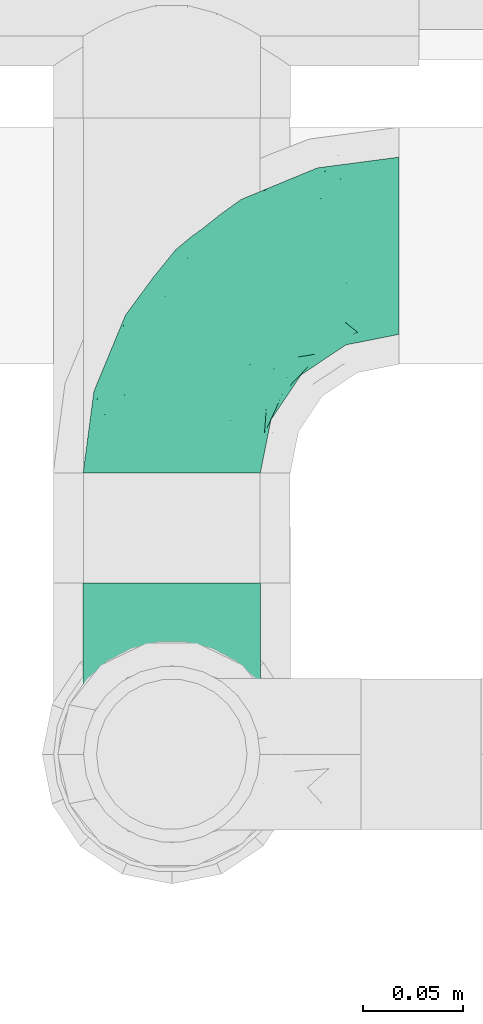
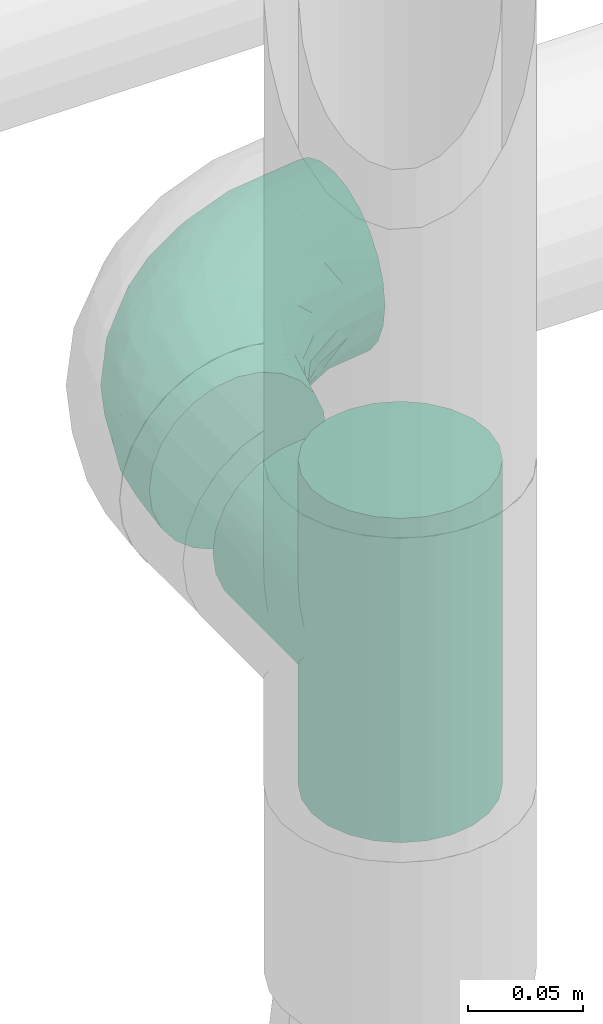
# One storey, part 707 of 827: 2 flow fittings.
"""IFC2X3 building model written with IfcOpenShell, lengths in millimetres."""

import ifcopenshell
import ifcopenshell.guid

model = None  # the IFC model being written
_history = None  # IfcOwnerHistory: only IFC2X3 demands one
_inside = {}  # id of a spatial element -> (the spatial element, [elements in it])
_under = {}  # id of a project, library or spatial element -> (it, [spatial elements below it])
_declared = {}  # id of a project -> (the project, [libraries it declares])
_typed = {}  # id of a type object -> (the type object, [elements of that type])
_made_of = {}  # id of a material, layer set ... -> (it, [elements and type objects made of it])


def new_model(schema):
    """Start an empty IFC model of exactly this schema.

    Asked for "IFC4X3", IfcOpenShell would pick the latest addendum, in which some entities
    have other attributes; the version numbers below select the first issue.
    IFC2X3 requires an IfcOwnerHistory on every rooted entity: one is made here for all.
    """
    global model, _history
    if schema == "IFC4X3":
        model = ifcopenshell.file(schema_version=(4, 3, 0, 0))
    else:
        model = ifcopenshell.file(schema=schema)
    _inside.clear()
    _under.clear()
    _declared.clear()
    _typed.clear()
    _made_of.clear()
    _history = None
    if model.schema == "IFC2X3":
        org = make("IfcOrganization", Name="unknown")
        user = make(
            "IfcPersonAndOrganization",
            ThePerson=make("IfcPerson", FamilyName="unknown"),
            TheOrganization=org,
        )
        app = make(
            "IfcApplication",
            ApplicationDeveloper=org,
            Version="unknown",
            ApplicationFullName="unknown",
            ApplicationIdentifier="unknown",
        )
        _history = make(
            "IfcOwnerHistory",
            OwningUser=user,
            OwningApplication=app,
            ChangeAction="ADDED",
            CreationDate=0,
        )
    return model


def make(cls, **values):
    """One entity of the class cls with the attributes given. An attribute that is None is left unset."""
    return model.create_entity(
        cls, **{name: value for name, value in values.items() if value is not None}
    )


def entity(cls, *values):
    """Any entity or typed value of the class cls, its attributes in the order of the schema. None: left unset."""
    e = model.create_entity(cls)
    for i, value in enumerate(values):
        if value is not None:
            e[i] = value
    return e


def rooted(cls, **values):
    """An entity with a GlobalId (a new one), such as an element, a storey or a relation."""
    return make(cls, GlobalId=ifcopenshell.guid.new(), OwnerHistory=_history, **values)


def si_unit(unit_type, name, prefix=None):
    """IfcSIUnit, for example si_unit("LENGTHUNIT", "METRE", prefix="MILLI")."""
    return make("IfcSIUnit", UnitType=unit_type, Prefix=prefix, Name=name)


def converted_unit(unit_type, name, factor, base, dimensions=None, offset=None):
    """IfcConversionBasedUnit, such as the inch: factor (a typed value) times the base unit."""
    return make(
        "IfcConversionBasedUnit"
        if offset is None
        else "IfcConversionBasedUnitWithOffset",
        ConversionOffset=offset,
        Dimensions=None
        if dimensions is None
        else entity("IfcDimensionalExponents", *dimensions),
        UnitType=unit_type,
        Name=name,
        ConversionFactor=make(
            "IfcMeasureWithUnit", ValueComponent=factor, UnitComponent=base
        ),
    )


def derived_unit(unit_type, elements):
    """IfcDerivedUnit: a product of units, each with its exponent."""
    return make(
        "IfcDerivedUnit",
        Elements=[
            make("IfcDerivedUnitElement", Unit=unit, Exponent=power)
            for unit, power in elements
        ],
        UnitType=unit_type,
    )


def assignment(units):
    """IfcUnitAssignment: the units of a project."""
    return None if units is None else make("IfcUnitAssignment", Units=units)


def point(xyz):
    """IfcCartesianPoint."""
    return None if xyz is None else make("IfcCartesianPoint", Coordinates=xyz)


def direction(xyz):
    """IfcDirection."""
    return None if xyz is None else make("IfcDirection", DirectionRatios=xyz)


def frame(location, z_axis=None, x_axis=None):
    """IfcAxis2Placement3D, a coordinate frame: its origin and axes. An axis left out is left unset."""
    return make(
        "IfcAxis2Placement3D",
        Location=point(location),
        Axis=direction(z_axis),
        RefDirection=direction(x_axis),
    )


def origin():
    """The frame at (0, 0, 0) with its axes left unset."""
    return frame((0.0, 0.0, 0.0))


def place(relative_to, where):
    """IfcLocalPlacement: puts the frame where relative to a parent placement (None: the world)."""
    return make(
        "IfcLocalPlacement", PlacementRelTo=relative_to, RelativePlacement=where
    )


def context(
    kind, dimensions, precision=None, world=None, true_north=None, identifier=None
):
    """IfcGeometricRepresentationContext, for example the 3D "Model" context."""
    return make(
        "IfcGeometricRepresentationContext",
        ContextIdentifier=identifier,
        ContextType=kind,
        CoordinateSpaceDimension=dimensions,
        Precision=precision,
        WorldCoordinateSystem=world,
        TrueNorth=true_north,
    )


def subcontext(parent, identifier, kind, view, scale=None):
    """IfcGeometricRepresentationSubContext, for example "Body" below "Model"."""
    return make(
        "IfcGeometricRepresentationSubContext",
        ContextIdentifier=identifier,
        ContextType=kind,
        ParentContext=parent,
        TargetScale=scale,
        TargetView=view,
    )


def project(units=None, contexts=None):
    """IfcProject with its units and contexts."""
    return rooted(
        "IfcProject",
        Name="project",
        RepresentationContexts=contexts,
        UnitsInContext=assignment(units),
    )


def spatial(cls, under=None, at=None, **own):
    """A site, building, storey or space (cls), placed at a placement, below another one or the project."""
    s = rooted(cls, ObjectPlacement=at, **own)
    if under is not None:
        _under.setdefault(under.id(), (under, []))[1].append(s)
    return s


def faces_of(points, faces, orient=None, outer=None):
    """IfcFace entities. A face is a list of loops; a loop is a list of indices into points, from 0.

    orient and outer hold one flag for each loop. By default every Orientation is true, the
    first loop of a face is its IfcFaceOuterBound and the others are IfcFaceBound.
    """
    made = []
    for i, loops in enumerate(faces):
        bounds = []
        for j, loop in enumerate(loops):
            is_outer = j == 0 if outer is None else outer[i][j]
            bounds.append(
                make(
                    "IfcFaceOuterBound" if is_outer else "IfcFaceBound",
                    Bound=make("IfcPolyLoop", Polygon=[points[k] for k in loop]),
                    Orientation=True if orient is None else orient[i][j],
                )
            )
        made.append(make("IfcFace", Bounds=bounds))
    return made


def faceted_brep(points, faces, orient=None, outer=None, voids=None):
    """IfcFacetedBrep: a solid bounded by flat faces; with voids (closed shells), ...WithVoids."""
    shared = [point(p) for p in points]
    hull = make("IfcClosedShell", CfsFaces=faces_of(shared, faces, orient, outer))
    if voids is None:
        return make("IfcFacetedBrep", Outer=hull)
    return make(
        "IfcFacetedBrepWithVoids",
        Outer=hull,
        Voids=[
            make(cls, CfsFaces=faces_of(shared, fs, o, b)) for cls, fs, o, b in voids
        ],
    )


def shape(context_of_items, identifier, shape_type, items):
    """IfcShapeRepresentation: the items that make up one representation, for example the "Body"."""
    return make(
        "IfcShapeRepresentation",
        ContextOfItems=context_of_items,
        RepresentationIdentifier=identifier,
        RepresentationType=shape_type,
        Items=items,
    )


def source(mapping_origin, context_of_items, identifier, shape_type, items):
    """IfcRepresentationMap: a shape defined once, which mapped items show again and again."""
    return make(
        "IfcRepresentationMap",
        MappingOrigin=mapping_origin,
        MappedRepresentation=shape(context_of_items, identifier, shape_type, items),
    )


def transform(
    local_origin,
    x_axis=None,
    y_axis=None,
    z_axis=None,
    scale=None,
    scale2=None,
    scale3=None,
    uniform=True,
):
    """IfcCartesianTransformationOperator3D, or its non-uniform kind. x_axis, y_axis, z_axis: its Axis1, 2, 3."""
    if uniform:
        return make(
            "IfcCartesianTransformationOperator3D",
            Axis1=direction(x_axis),
            Axis2=direction(y_axis),
            LocalOrigin=point(local_origin),
            Scale=scale,
            Axis3=direction(z_axis),
        )
    return make(
        "IfcCartesianTransformationOperator3DnonUniform",
        Axis1=direction(x_axis),
        Axis2=direction(y_axis),
        LocalOrigin=point(local_origin),
        Scale=scale,
        Axis3=direction(z_axis),
        Scale2=scale2,
        Scale3=scale3,
    )


def mapped(mapping_source, mapping_target):
    """IfcMappedItem: shows the shape of a source again, moved by a transform."""
    return make(
        "IfcMappedItem", MappingSource=mapping_source, MappingTarget=mapping_target
    )


def material(Name=None, Category=None):
    """IfcMaterial."""
    return make("IfcMaterial", Name=Name, Category=Category)


def made_of(thing, what):
    """Note that an element or type object is made of a material, layer set ...; save() writes the relation."""
    if what is not None:
        _made_of.setdefault(what.id(), (what, []))[1].append(thing)
    return thing


def type_object(cls, material=None, **own):
    """A type object (cls), such as IfcWallType, which elements share."""
    return made_of(rooted(cls, **own), material)


def type_shapes(of_type, sources):
    """Give a type object the sources (RepresentationMaps) that its elements show as mapped items."""
    of_type.RepresentationMaps = sources


def element(
    cls,
    number,
    at=None,
    inside=None,
    cuts=None,
    type_object=None,
    material=None,
    context=None,
    identifier="Body",
    shape_type=None,
    held_by="IfcProductDefinitionShape",
    body=None,
    shapes=None,
    **own,
):
    """One element of the class cls, such as IfcWall. Its Tag is "e" and its number.

    at: its placement. inside: the storey or other place that contains it. cuts: it is an
    opening in that element (IfcRelVoidsElement). A single representation is given by context,
    identifier, shape_type and body (its items); several are given by shapes. held_by: the class
    of the entity that holds the representations. save() writes the other relations.
    """
    e = rooted(cls, Tag="e%d" % number, ObjectPlacement=at, **own)
    if body is not None:
        shapes = [shape(context, identifier, shape_type, body)]
    if shapes is not None:
        e.Representation = make(held_by, Representations=shapes)
    if inside is not None:
        _inside.setdefault(inside.id(), (inside, []))[1].append(e)
    if cuts is not None:
        rooted(
            "IfcRelVoidsElement", RelatingBuildingElement=cuts, RelatedOpeningElement=e
        )
    if type_object is not None:
        _typed.setdefault(type_object.id(), (type_object, []))[1].append(e)
    return made_of(e, material)


def aggregate(whole, parts):
    """IfcRelAggregates: a whole, such as a stair, and the parts it consists of."""
    return rooted("IfcRelAggregates", RelatingObject=whole, RelatedObjects=parts)


def save(model, path):
    """Write the relations noted so far, then the file.

    IfcRelAggregates (storeys below a building ...), IfcRelContainedInSpatialStructure (elements
    in a storey), IfcRelDefinesByType, IfcRelAssociatesMaterial and IfcRelDeclares: one each for
    every whole, place, type object, material and project.
    """
    for whole, parts in _under.values():
        aggregate(whole, parts)
    for where, things in _inside.values():
        rooted(
            "IfcRelContainedInSpatialStructure",
            RelatedElements=things,
            RelatingStructure=where,
        )
    for kind, things in _typed.values():
        rooted("IfcRelDefinesByType", RelatedObjects=things, RelatingType=kind)
    for what, things in _made_of.values():
        rooted("IfcRelAssociatesMaterial", RelatedObjects=things, RelatingMaterial=what)
    for by, libraries in _declared.values():
        rooted("IfcRelDeclares", RelatingContext=by, RelatedDefinitions=libraries)
    model.write(path)


model = new_model("IFC2X3")

# Units and contexts
model_context = context("Model", 3, precision=0.01, world=origin(), true_north=direction((6.12303176911189e-17, 1.0)))
body_context = subcontext(model_context, "Body", "Model", "MODEL_VIEW")
ifc_project = project(units=[si_unit("LENGTHUNIT", "METRE", prefix="MILLI"), si_unit("AREAUNIT", "SQUARE_METRE"), si_unit("VOLUMEUNIT", "CUBIC_METRE"), converted_unit("PLANEANGLEUNIT", "DEGREE", entity("IfcRatioMeasure", 0.0174532925199433), si_unit("PLANEANGLEUNIT", "RADIAN"), dimensions=[0, 0, 0, 0, 0, 0, 0]), si_unit("MASSUNIT", "GRAM", prefix="KILO"), derived_unit("MASSDENSITYUNIT", [(si_unit("MASSUNIT", "GRAM", prefix="KILO"), 1), (si_unit("LENGTHUNIT", "METRE"), -3)]), derived_unit("MOMENTOFINERTIAUNIT", [(si_unit("LENGTHUNIT", "METRE"), 4)]), si_unit("TIMEUNIT", "SECOND"), si_unit("FREQUENCYUNIT", "HERTZ"), si_unit("THERMODYNAMICTEMPERATUREUNIT", "DEGREE_CELSIUS"), derived_unit("THERMALTRANSMITTANCEUNIT", [(si_unit("MASSUNIT", "GRAM", prefix="KILO"), 1), (si_unit("THERMODYNAMICTEMPERATUREUNIT", "KELVIN"), -1), (si_unit("TIMEUNIT", "SECOND"), -3)]), derived_unit("VOLUMETRICFLOWRATEUNIT", [(si_unit("LENGTHUNIT", "METRE"), 3), (si_unit("TIMEUNIT", "SECOND"), -1)]), derived_unit("MASSFLOWRATEUNIT", [(si_unit("MASSUNIT", "GRAM", prefix="KILO"), 1), (si_unit("TIMEUNIT", "SECOND"), -1)]), derived_unit("ROTATIONALFREQUENCYUNIT", [(si_unit("TIMEUNIT", "SECOND"), -1)]), si_unit("ELECTRICCURRENTUNIT", "AMPERE"), si_unit("ELECTRICVOLTAGEUNIT", "VOLT"), si_unit("POWERUNIT", "WATT"), si_unit("FORCEUNIT", "NEWTON", prefix="KILO"), si_unit("ILLUMINANCEUNIT", "LUX"), si_unit("LUMINOUSFLUXUNIT", "LUMEN"), si_unit("LUMINOUSINTENSITYUNIT", "CANDELA"), derived_unit("USERDEFINED", [(si_unit("MASSUNIT", "GRAM", prefix="KILO"), -1), (si_unit("LENGTHUNIT", "METRE"), -2), (si_unit("TIMEUNIT", "SECOND"), 3), (si_unit("LUMINOUSFLUXUNIT", "LUMEN"), 1)]), derived_unit("LINEARVELOCITYUNIT", [(si_unit("LENGTHUNIT", "METRE"), 1), (si_unit("TIMEUNIT", "SECOND"), -1)]), si_unit("PRESSUREUNIT", "PASCAL"), derived_unit("USERDEFINED", [(si_unit("LENGTHUNIT", "METRE"), -2), (si_unit("MASSUNIT", "GRAM", prefix="KILO"), 1), (si_unit("TIMEUNIT", "SECOND"), -2)]), derived_unit("LINEARFORCEUNIT", [(si_unit("MASSUNIT", "GRAM", prefix="KILO"), 1), (si_unit("LENGTHUNIT", "METRE"), 1), (si_unit("TIMEUNIT", "SECOND"), -2), (si_unit("LENGTHUNIT", "METRE"), -1)]), derived_unit("PLANARFORCEUNIT", [(si_unit("MASSUNIT", "GRAM", prefix="KILO"), 1), (si_unit("LENGTHUNIT", "METRE"), 1), (si_unit("TIMEUNIT", "SECOND"), -2), (si_unit("LENGTHUNIT", "METRE"), -2)])], contexts=[model_context])

# Site, building, storey
site_placement = place(None, origin())
site = spatial("IfcSite", under=ifc_project, at=site_placement, CompositionType="ELEMENT")
building_placement = place(site_placement, origin())
building = spatial("IfcBuilding", under=site, at=building_placement, CompositionType="ELEMENT")
storey_placement = place(building_placement, frame((0.0, 0.0, 28200.0)))
storey = spatial("IfcBuildingStorey", under=building, at=storey_placement, Name="08", CompositionType="ELEMENT", Elevation=28200.0)

# Flow fittings
ifc_material = material()
pipe_fitting_type_1 = type_object("IfcPipeFittingType", Name="ADSK_1", PredefinedType="NOTDEFINED", material=ifc_material)
shared_shape_1 = source(origin(), body_context, "Body", "Brep", [
    faceted_brep([(-114.0, 22.22, -38.49), (-114.0, 11.5, -42.94), (-114.0, 0.0, -44.45), (-114.0, -11.5, -42.94), (-114.0, -22.23, -38.49), (-114.0, -31.43, -31.43), (-114.0, -38.49, -22.23), (-114.0, -42.94, -11.5), (-114.0, -44.45, 0.0), (-114.0, -42.94, 11.5), (-114.0, -38.49, 22.22), (-114.0, -31.43, 31.43), (-114.0, -22.23, 38.49), (-114.0, -11.5, 42.94), (-114.0, 0.0, 44.45), (-114.0, 11.5, 42.94), (-114.0, 22.22, 38.49), (-114.0, 31.43, 31.43), (-114.0, 38.49, 22.22), (-114.0, 42.94, 11.5), (-114.0, 44.45, 0.0), (-114.0, 42.94, -11.5), (-114.0, 38.49, -22.23), (-114.0, 31.43, -31.43), (0.0, 114.0, -44.45), (-11.5, 114.0, -42.94), (-22.22, 114.0, -38.49), (-31.43, 114.0, -31.43), (-38.49, 114.0, -22.23), (-42.94, 114.0, -11.5), (-44.45, 114.0, 0.0), (-42.94, 114.0, 11.5), (-38.49, 114.0, 22.22), (-31.43, 114.0, 31.43), (-22.22, 114.0, 38.49), (-11.5, 114.0, 42.94), (0.0, 114.0, 44.45), (11.5, 114.0, 42.94), (22.23, 114.0, 38.49), (31.43, 114.0, 31.43), (38.49, 114.0, 22.22), (42.94, 114.0, 11.5), (44.45, 114.0, 0.0), (42.94, 114.0, -11.5), (38.49, 114.0, -22.23), (31.43, 114.0, -31.43), (22.23, 114.0, -38.49), (11.5, 114.0, -42.94), (-24.5, -15.82, 8.24), (-7.18, -2.06, 7.97), (-13.53, -4.79, 15.72), (-92.03, -41.56, 0.0), (-77.08, -37.56, 14.57), (23.74, 74.96, 33.55), (-72.99, -39.05, 0.0), (-84.56, -15.6, 40.23), (-47.88, -6.37, 37.83), (-59.8, 2.77, 43.37), (-84.46, -33.54, 25.41), (16.69, 49.28, 31.02), (6.37, 47.88, 37.83), (3.35, 25.47, 29.77), (-47.43, 81.55, 19.51), (-74.96, -23.74, 33.55), (-46.77, -27.89, 11.23), (-53.88, -31.14, 0.0), (-87.05, 38.52, 28.81), (-63.44, 55.78, 24.79), (-93.24, 43.37, 18.58), (-16.67, 16.67, 37.64), (-25.47, -3.35, 29.77), (-17.2, 97.7, 41.53), (-7.42, 85.54, 44.3), (-67.09, 46.29, 31.23), (-18.08, 42.1, 44.06), (-32.93, 14.9, 42.17), (-11.54, 34.94, 41.69), (-95.7, 27.79, 36.14), (-88.55, -4.92, 43.79), (-2.77, 59.8, 43.37), (-87.65, 48.44, 9.87), (-81.01, 8.37, 44.32), (-37.63, 90.26, 28.6), (-51.29, 61.56, 30.59), (-29.32, 87.72, 36.52), (23.49, 49.5, 23.28), (8.19, 20.11, 19.18), (-70.06, 58.9, 9.01), (-87.38, 49.74, 0.0), (-88.15, 18.57, 41.8), (-7.96, 6.22, 24.33), (33.54, 84.46, 25.41), (37.56, 77.08, 14.57), (-58.37, 34.98, 40.92), (-62.38, 23.02, 43.45), (24.15, 39.93, 12.16), (31.14, 53.88, 0.0), (-58.13, 14.61, 44.45), (-37.17, 26.09, 44.37), (4.92, 88.55, 43.79), (-34.77, -23.22, 0.0), (-49.5, -23.49, 23.28), (41.56, 92.03, 0.0), (-57.83, 66.03, 19.12), (-71.84, 54.46, 17.06), (-46.46, 94.23, 8.51), (-49.74, 87.38, 0.0), (-38.96, 59.98, 38.88), (-55.29, 46.95, 36.83), (-64.82, 64.82, 0.0), (-55.88, 73.75, 10.01), (15.6, 84.56, 40.23), (-21.6, 76.38, 42.11), (-49.04, -15.53, 31.95), (-19.97, 55.59, 44.33), (-73.61, 33.95, 37.2), (-31.05, 58.14, 42.19), (-41.3, 41.3, 43.02), (-27.36, -11.22, 22.61), (9.28, 15.84, 8.73), (23.22, 34.77, 0.0), (39.05, 72.99, 0.0), (-1.96, 1.96, 0.0), (10.63, 18.37, 0.0), (-18.37, -10.63, 0.0), (-97.7, 17.2, -41.53), (9.28, 15.84, -8.73), (-13.53, -4.79, -15.72), (8.19, 20.11, -19.18), (-85.54, 7.42, -44.3), (-8.37, 81.01, -44.32), (-90.26, 37.63, -28.6), (-87.72, 29.32, -36.52), (-27.79, 95.7, -36.14), (-38.52, 87.05, -28.81), (-94.23, 46.46, -8.51), (-84.56, -15.6, -40.23), (-73.75, 55.88, -10.01), (-10.19, -4.86, -7.51), (-76.38, 21.6, -42.11), (-59.98, 38.96, -38.88), (-49.28, -16.69, -31.02), (-47.88, -6.37, -37.83), (-25.47, -3.35, -29.77), (-34.98, 58.37, -40.92), (-46.95, 55.29, -36.83), (-77.08, -37.56, -14.57), (-18.57, 88.15, -41.8), (-23.02, 62.38, -43.45), (-55.78, 63.44, -24.79), (-43.37, 93.24, -18.58), (-84.46, -33.54, -25.41), (-33.95, 73.61, -37.2), (-46.29, 67.09, -31.23), (-74.96, -23.74, -33.55), (-48.44, 87.65, -9.87), (-45.44, -27.06, -11.87), (-88.55, -4.92, -43.79), (-49.5, -23.49, -23.28), (-14.61, 58.13, -44.45), (-26.09, 37.17, -44.37), (15.6, 84.56, -40.23), (6.37, 47.88, -37.83), (-2.77, 59.8, -43.37), (-81.55, 47.43, -19.51), (33.54, 84.46, -25.41), (23.49, 49.5, -23.28), (23.74, 74.96, -33.55), (-42.1, 18.08, -44.06), (-14.9, 32.93, -42.17), (-34.94, 11.54, -41.69), (-61.56, 51.29, -30.59), (-27.36, -11.22, -22.61), (37.56, 77.08, -14.57), (4.92, 88.55, -43.79), (-59.8, 2.77, -43.37), (-66.03, 57.83, -19.12), (-54.46, 71.84, -17.06), (-55.59, 19.97, -44.33), (-58.9, 70.06, -9.01), (24.15, 39.93, -12.16), (15.53, 49.04, -31.95), (-58.14, 31.05, -42.19), (-41.3, 41.3, -43.02), (-16.67, 16.67, -37.64), (3.35, 25.47, -29.77), (-7.96, 6.22, -24.33), (-26.36, -16.33, -11.05)], [[[0, 1, 2, 3, 4, 5, 6, 7, 8, 9, 10, 11, 12, 13, 14, 15, 16, 17, 18, 19, 20, 21, 22, 23]], [[24, 25, 26, 27, 28, 29, 30, 31, 32, 33, 34, 35, 36, 37, 38, 39, 40, 41, 42, 43, 44, 45, 46, 47]], [[48, 49, 50]], [[51, 52, 9]], [[53, 39, 38]], [[9, 52, 10]], [[54, 52, 51]], [[55, 56, 57]], [[11, 10, 58]], [[59, 60, 61]], [[32, 31, 62]], [[63, 12, 11]], [[63, 55, 12]], [[64, 52, 65]], [[66, 67, 68]], [[69, 56, 70]], [[35, 71, 72]], [[67, 66, 73]], [[74, 75, 76]], [[16, 77, 17]], [[13, 78, 14]], [[76, 79, 74]], [[68, 80, 19]], [[18, 17, 66]], [[14, 78, 81]], [[20, 19, 80]], [[82, 83, 84]], [[85, 61, 86]], [[87, 88, 80]], [[18, 68, 19]], [[15, 89, 16]], [[14, 81, 15]], [[70, 90, 61]], [[17, 77, 66]], [[91, 85, 92]], [[93, 89, 94]], [[95, 96, 92]], [[84, 71, 34]], [[94, 97, 98]], [[37, 36, 99]], [[40, 39, 91]], [[40, 92, 41]], [[65, 100, 64]], [[91, 92, 40]], [[58, 101, 63]], [[92, 102, 41]], [[92, 85, 95]], [[67, 103, 104]], [[34, 33, 84]], [[105, 62, 31]], [[52, 58, 10]], [[106, 105, 30]], [[93, 107, 108]], [[106, 109, 110]], [[53, 111, 60]], [[84, 112, 71]], [[84, 107, 112]], [[33, 82, 84]], [[12, 55, 13]], [[113, 56, 63]], [[111, 38, 37]], [[34, 71, 35]], [[36, 35, 72]], [[112, 114, 72]], [[110, 105, 106]], [[111, 53, 38]], [[115, 108, 73]], [[89, 15, 81]], [[104, 87, 80]], [[110, 87, 103]], [[33, 32, 82]], [[116, 107, 117]], [[112, 116, 114]], [[99, 72, 79]], [[56, 55, 63]], [[78, 55, 57]], [[101, 118, 113]], [[56, 69, 75]], [[99, 111, 37]], [[79, 76, 60]], [[79, 60, 111]], [[60, 69, 61]], [[101, 58, 52]], [[63, 11, 58]], [[39, 53, 91]], [[85, 91, 53]], [[94, 89, 81]], [[77, 89, 115]], [[84, 83, 107]], [[93, 108, 115]], [[98, 114, 117]], [[79, 72, 114]], [[98, 117, 94]], [[98, 57, 75]], [[32, 62, 82]], [[83, 82, 62]], [[70, 113, 118]], [[61, 85, 59]], [[48, 64, 100]], [[95, 119, 120]], [[69, 70, 61]], [[70, 118, 90]], [[72, 99, 36]], [[111, 99, 79]], [[55, 78, 13]], [[81, 78, 57]], [[94, 81, 97]], [[93, 94, 117]], [[66, 68, 18]], [[80, 68, 104]], [[103, 87, 104]], [[80, 88, 20]], [[50, 49, 119]], [[95, 85, 86]], [[119, 95, 86]], [[121, 92, 96]], [[50, 119, 86]], [[119, 122, 123, 120]], [[110, 109, 87]], [[88, 87, 109]], [[62, 105, 110]], [[30, 105, 31]], [[81, 57, 97]], [[57, 98, 97]], [[107, 93, 117]], [[89, 93, 115]], [[107, 83, 108]], [[73, 108, 83]], [[67, 73, 83]], [[115, 73, 66]], [[103, 83, 62]], [[67, 104, 68]], [[83, 103, 67]], [[110, 103, 62]], [[89, 77, 16]], [[66, 77, 115]], [[56, 75, 57]], [[76, 75, 69]], [[60, 76, 69]], [[79, 114, 74]], [[114, 98, 74]], [[75, 74, 98]], [[9, 8, 51]], [[102, 92, 121]], [[102, 42, 41]], [[72, 71, 112]], [[52, 54, 65]], [[64, 48, 118]], [[101, 52, 64]], [[124, 122, 49]], [[118, 48, 50]], [[49, 48, 124]], [[119, 49, 122]], [[48, 100, 124]], [[114, 116, 117]], [[112, 107, 116]], [[101, 113, 63]], [[70, 56, 113]], [[64, 118, 101]], [[90, 50, 86]], [[50, 90, 118]], [[61, 90, 86]], [[85, 53, 59]], [[60, 59, 53]], [[95, 120, 96]], [[125, 1, 0]], [[126, 127, 128]], [[2, 1, 129]], [[24, 130, 25]], [[131, 132, 23]], [[27, 133, 134]], [[88, 135, 20]], [[136, 4, 3]], [[88, 109, 137]], [[138, 122, 124]], [[139, 132, 140]], [[141, 142, 143]], [[144, 140, 145]], [[125, 132, 139]], [[6, 146, 7]], [[144, 147, 148]], [[146, 51, 7]], [[134, 149, 150]], [[146, 6, 151]], [[152, 145, 153]], [[154, 4, 136]], [[154, 136, 142]], [[150, 155, 29]], [[43, 42, 102]], [[65, 146, 156]], [[0, 23, 132]], [[157, 3, 2]], [[146, 151, 158]], [[148, 159, 160]], [[161, 162, 163]], [[135, 164, 21]], [[165, 166, 167]], [[168, 169, 170]], [[147, 25, 130]], [[171, 132, 131]], [[155, 30, 29]], [[172, 141, 143]], [[134, 28, 27]], [[149, 134, 153]], [[173, 165, 44]], [[26, 25, 147]], [[22, 21, 164]], [[24, 174, 130]], [[133, 27, 26]], [[170, 175, 168]], [[24, 47, 174]], [[45, 167, 46]], [[28, 150, 29]], [[1, 125, 129]], [[156, 100, 65]], [[165, 45, 44]], [[161, 46, 167]], [[173, 44, 43]], [[6, 5, 151]], [[173, 102, 121]], [[137, 135, 88]], [[46, 161, 47]], [[102, 173, 43]], [[149, 176, 177]], [[172, 158, 141]], [[139, 178, 129]], [[154, 5, 4]], [[156, 146, 158]], [[106, 155, 179]], [[173, 96, 180]], [[181, 162, 167]], [[177, 179, 155]], [[137, 179, 176]], [[23, 22, 131]], [[182, 140, 183]], [[139, 182, 178]], [[157, 129, 175]], [[157, 136, 3]], [[175, 170, 142]], [[175, 142, 136]], [[142, 184, 143]], [[162, 161, 167]], [[174, 161, 163]], [[181, 166, 185]], [[162, 184, 169]], [[5, 154, 151]], [[158, 151, 154]], [[166, 165, 173]], [[167, 45, 165]], [[148, 147, 130]], [[133, 147, 152]], [[132, 171, 140]], [[144, 145, 152]], [[160, 178, 183]], [[175, 129, 178]], [[160, 183, 148]], [[160, 163, 169]], [[22, 164, 131]], [[171, 131, 164]], [[162, 185, 184]], [[186, 127, 172]], [[185, 128, 186]], [[156, 187, 100]], [[185, 166, 128]], [[143, 184, 185]], [[129, 157, 2]], [[136, 157, 175]], [[161, 174, 47]], [[130, 174, 163]], [[148, 130, 159]], [[144, 148, 183]], [[134, 150, 28]], [[155, 150, 177]], [[176, 179, 177]], [[155, 106, 30]], [[166, 180, 128]], [[128, 180, 126]], [[173, 180, 166]], [[126, 120, 123, 122]], [[120, 126, 180]], [[122, 138, 126]], [[137, 109, 179]], [[106, 179, 109]], [[164, 135, 137]], [[20, 135, 21]], [[130, 163, 159]], [[163, 160, 159]], [[140, 144, 183]], [[147, 144, 152]], [[140, 171, 145]], [[153, 145, 171]], [[149, 153, 171]], [[152, 153, 134]], [[176, 171, 164]], [[149, 177, 150]], [[171, 176, 149]], [[137, 176, 164]], [[147, 133, 26]], [[134, 133, 152]], [[162, 169, 163]], [[170, 169, 184]], [[142, 170, 184]], [[175, 178, 168]], [[178, 160, 168]], [[169, 168, 160]], [[51, 146, 54]], [[51, 8, 7]], [[132, 125, 0]], [[129, 125, 139]], [[156, 158, 172]], [[65, 54, 146]], [[178, 182, 183]], [[139, 140, 182]], [[158, 154, 141]], [[142, 141, 154]], [[186, 172, 143]], [[172, 127, 187]], [[185, 186, 143]], [[127, 186, 128]], [[187, 127, 138]], [[124, 100, 187]], [[126, 138, 127]], [[187, 138, 124]], [[172, 187, 156]], [[166, 181, 167]], [[185, 162, 181]], [[96, 173, 121]], [[96, 120, 180]]]),
])
type_shapes(pipe_fitting_type_1, [shared_shape_1])
flow_fitting_1_placement = place(storey_placement, frame((57447.89, 17755.1, 2100.0), z_axis=(0.0, 0.0, 1.0), x_axis=(-1.0, 0.0, 0.0)))
element("IfcFlowFitting", 1, at=flow_fitting_1_placement, inside=storey, type_object=pipe_fitting_type_1, material=ifc_material, Name="ADSK_1", ObjectType="ADSK_1", context=body_context, shape_type="MappedRepresentation", body=[
    mapped(shared_shape_1, transform((0.0, 0.0, 0.0), scale=1.0)),
])
pipe_fitting_type_2 = type_object("IfcPipeFittingType", Name="ADSK_1", PredefinedType="NOTDEFINED", material=ifc_material)
shared_shape_2 = source(origin(), body_context, "Body", "Brep", [
    faceted_brep([(-86.0, 22.22, -38.49), (-86.0, 11.5, -42.94), (-86.0, 0.0, -44.45), (-86.0, -11.5, -42.94), (-86.0, -22.23, -38.49), (-86.0, -26.83, -34.96), (-86.0, -31.43, -31.43), (-86.0, -34.96, -26.83), (-86.0, -38.49, -22.23), (-86.0, -40.72, -16.86), (-86.0, -42.94, -11.5), (-86.0, -44.45, 0.0), (-86.0, -42.94, 11.5), (-86.0, -40.72, 16.86), (-86.0, -38.49, 22.22), (-86.0, -34.96, 26.83), (-86.0, -31.43, 31.43), (-86.0, -26.83, 34.96), (-86.0, -22.23, 38.49), (-86.0, -11.5, 42.94), (-86.0, 0.0, 44.45), (-86.0, 11.5, 42.94), (-86.0, 22.22, 38.49), (-86.0, 31.43, 31.43), (-86.0, 38.49, 22.22), (-86.0, 42.94, 11.5), (-86.0, 44.45, 0.0), (-86.0, 42.94, -11.5), (-86.0, 38.49, -22.23), (-86.0, 31.43, -31.43), (86.0, 0.0, -44.45), (86.0, 11.5, -42.94), (86.0, 22.22, -38.49), (86.0, 31.43, -31.43), (86.0, 38.49, -22.23), (86.0, 42.94, -11.5), (86.0, 44.45, 0.0), (86.0, 42.94, 11.5), (86.0, 38.49, 22.22), (86.0, 31.43, 31.43), (86.0, 22.22, 38.49), (86.0, 11.5, 42.94), (86.0, 0.0, 44.45), (86.0, -11.5, 42.94), (86.0, -22.23, 38.49), (86.0, -26.83, 34.96), (86.0, -31.43, 31.43), (86.0, -34.96, 26.83), (86.0, -38.49, 22.22), (86.0, -40.72, 16.86), (86.0, -42.94, 11.5), (86.0, -44.45, 0.0), (86.0, -42.94, -11.5), (86.0, -40.72, -16.86), (86.0, -38.49, -22.23), (86.0, -34.96, -26.83), (86.0, -31.43, -31.43), (86.0, -26.83, -34.96), (86.0, -22.23, -38.49), (86.0, -11.5, -42.94), (43.21, -43.21, 10.43), (44.45, -44.45, 0.0), (-43.21, -43.21, 10.43), (-44.45, -44.45, 0.0), (41.49, -41.49, 15.14), (39.77, -39.77, 19.85), (21.97, -21.97, 38.64), (34.75, -34.75, 27.71), (28.69, -28.69, 33.95), (-41.49, -41.49, 15.14), (-39.77, -39.77, 19.85), (-21.97, -21.97, 38.64), (-34.75, -34.75, 27.71), (-28.69, -28.69, 33.95), (-14.84, -14.84, 41.9), (7.47, -7.47, 43.82), (14.84, -14.84, 41.9), (0.0, 0.0, 44.45), (-7.47, -7.47, 43.82), (7.47, -7.47, -43.82), (0.0, 0.0, -44.45), (14.84, -14.84, -41.9), (-28.69, -28.69, -33.95), (-7.47, -7.47, -43.82), (-41.49, -41.49, -15.14), (-43.21, -43.21, -10.43), (-34.75, -34.75, -27.71), (-14.84, -14.84, -41.9), (21.97, -21.97, -38.64), (28.69, -28.69, -33.95), (-39.77, -39.77, -19.85), (34.75, -34.75, -27.71), (43.21, -43.21, -10.43), (41.49, -41.49, -15.14), (39.77, -39.77, -19.85), (-21.97, -21.97, -38.64), (31.43, -86.0, -31.43), (38.49, -86.0, -22.23), (42.94, -86.0, -11.5), (44.45, -86.0, 0.0), (42.94, -86.0, 11.5), (38.49, -86.0, 22.22), (31.43, -86.0, 31.43), (22.23, -86.0, 38.49), (11.5, -86.0, 42.94), (0.0, -86.0, 44.45), (-11.5, -86.0, 42.94), (-22.22, -86.0, 38.49), (-31.43, -86.0, 31.43), (-38.49, -86.0, 22.22), (-42.94, -86.0, 11.5), (-44.45, -86.0, 0.0), (-42.94, -86.0, -11.5), (-38.49, -86.0, -22.23), (-31.43, -86.0, -31.43), (-22.22, -86.0, -38.49), (-11.5, -86.0, -42.94), (0.0, -86.0, -44.45), (11.5, -86.0, -42.94), (22.23, -86.0, -38.49)], [[[0, 1, 2, 3, 4, 5, 6, 7, 8, 9, 10, 11, 12, 13, 14, 15, 16, 17, 18, 19, 20, 21, 22, 23, 24, 25, 26, 27, 28, 29]], [[30, 31, 32, 33, 34, 35, 36, 37, 38, 39, 40, 41, 42, 43, 44, 45, 46, 47, 48, 49, 50, 51, 52, 53, 54, 55, 56, 57, 58, 59]], [[51, 50, 60]], [[60, 61, 51]], [[62, 11, 63]], [[50, 49, 64]], [[49, 48, 65]], [[44, 66, 45]], [[46, 67, 48, 47]], [[67, 46, 68]], [[48, 67, 65]], [[68, 46, 45]], [[12, 69, 13]], [[70, 13, 69]], [[11, 62, 12]], [[12, 62, 69]], [[71, 18, 17]], [[72, 73, 16]], [[72, 16, 15, 14]], [[16, 73, 17]], [[71, 74, 18]], [[72, 14, 70]], [[49, 65, 64]], [[45, 66, 68]], [[43, 42, 75]], [[50, 64, 60]], [[66, 44, 76]], [[75, 76, 43]], [[75, 42, 77]], [[78, 77, 20]], [[76, 44, 43]], [[24, 23, 39, 38]], [[25, 24, 38, 37]], [[22, 21, 41, 40]], [[23, 22, 40, 39]], [[41, 21, 20, 77, 42]], [[26, 25, 37, 36]], [[70, 14, 13]], [[78, 19, 74]], [[19, 78, 20]], [[19, 18, 74]], [[71, 17, 73]], [[29, 28, 34, 33]], [[27, 35, 34, 28]], [[26, 36, 35, 27]], [[0, 29, 33, 32]], [[30, 59, 79]], [[31, 30, 80, 2, 1]], [[79, 59, 81]], [[82, 6, 5]], [[32, 31, 1, 0]], [[59, 58, 81]], [[30, 79, 80]], [[80, 83, 2]], [[10, 84, 85]], [[86, 8, 7, 6]], [[83, 87, 3]], [[2, 83, 3]], [[87, 4, 3]], [[88, 57, 89]], [[57, 56, 89]], [[9, 90, 84]], [[88, 58, 57]], [[91, 89, 56]], [[55, 54, 91, 56]], [[58, 88, 81]], [[52, 92, 93]], [[92, 52, 51]], [[94, 53, 93]], [[61, 92, 51]], [[85, 63, 11]], [[54, 94, 91]], [[82, 5, 95]], [[52, 93, 53]], [[5, 4, 95]], [[6, 82, 86]], [[94, 54, 53]], [[95, 4, 87]], [[10, 9, 84]], [[90, 9, 8]], [[10, 85, 11]], [[90, 8, 86]], [[96, 97, 98, 99, 100, 101, 102, 103, 104, 105, 106, 107, 108, 109, 110, 111, 112, 113, 114, 115, 116, 117, 118, 119]], [[62, 63, 111]], [[110, 62, 111]], [[108, 107, 73]], [[72, 109, 108]], [[70, 110, 109]], [[74, 107, 106]], [[110, 70, 69, 62]], [[73, 72, 108]], [[70, 109, 72]], [[74, 71, 107]], [[105, 77, 78]], [[74, 106, 78]], [[73, 107, 71]], [[78, 106, 105]], [[75, 105, 104]], [[103, 76, 104]], [[101, 100, 65]], [[67, 102, 101]], [[68, 103, 102]], [[60, 100, 99]], [[68, 66, 103]], [[76, 75, 104]], [[66, 76, 103]], [[61, 60, 99]], [[65, 67, 101]], [[100, 60, 64, 65]], [[68, 102, 67]], [[105, 75, 77]], [[61, 99, 92]], [[98, 92, 99]], [[96, 119, 89]], [[94, 98, 97]], [[96, 91, 97]], [[81, 119, 118]], [[98, 94, 93, 92]], [[89, 91, 96]], [[94, 97, 91]], [[81, 88, 119]], [[117, 80, 79]], [[81, 118, 79]], [[89, 119, 88]], [[79, 118, 117]], [[83, 117, 116]], [[115, 87, 116]], [[113, 112, 90]], [[86, 114, 113]], [[82, 115, 114]], [[85, 112, 111]], [[82, 95, 115]], [[87, 83, 116]], [[95, 87, 115]], [[63, 85, 111]], [[90, 86, 113]], [[112, 85, 84, 90]], [[82, 114, 86]], [[117, 83, 80]]]),
])
type_shapes(pipe_fitting_type_2, [shared_shape_2])
flow_fitting_2_placement = place(storey_placement, frame((57447.89, 17500.0, 2100.0), z_axis=(1.0, 0.0, 0.0), x_axis=(0.0, 0.0, 1.0)))
element("IfcFlowFitting", 2, at=flow_fitting_2_placement, inside=storey, type_object=pipe_fitting_type_2, material=ifc_material, Name="ADSK_1", ObjectType="ADSK_1", context=body_context, shape_type="MappedRepresentation", body=[
    mapped(shared_shape_2, transform((0.0, 0.0, 0.0), scale=1.0)),
])

save(model, "model.ifc")
